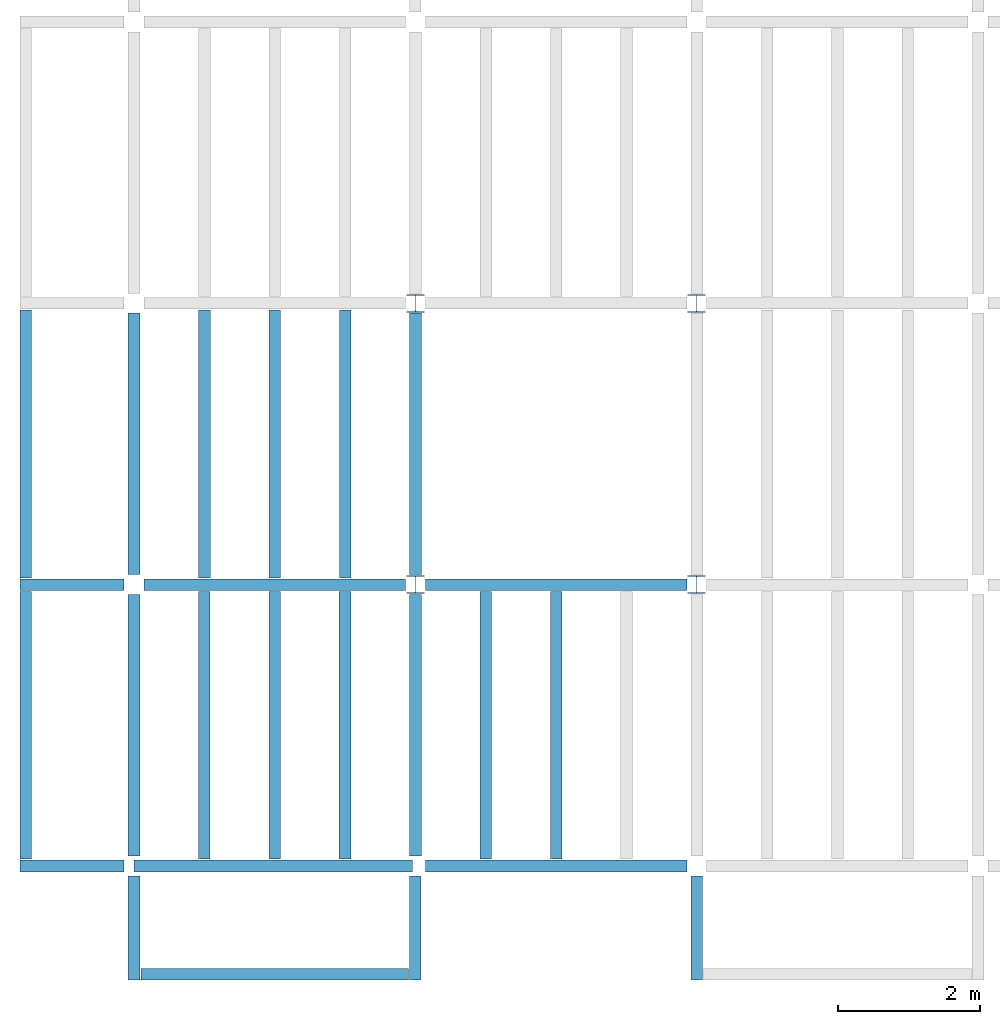
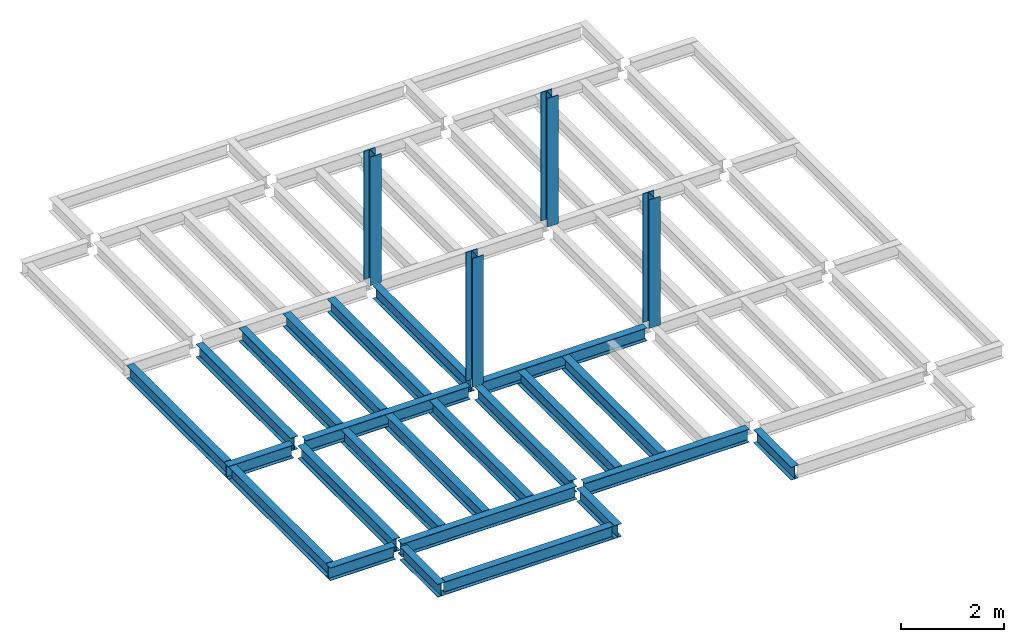
# One storey, part 1 of 3: 24 beams, 4 columns, 3 elements without a shape of their own.
"""IFC4 building model written with IfcOpenShell, lengths in feet."""

from ifc_helpers import new_model, entity, si_unit, converted_unit, derived_unit, direction, frame, origin, origin_2d, place, context, subcontext, project, spatial, line, arc, indexed_curve, i_section, outline, extrude, source, transform, mapped, material, type_object, type_shapes, element, aggregate, save


model = new_model("IFC4")

# Units and contexts
model_context = context("Model", 3, precision=0.0001, world=origin(), true_north=direction((6.123233995736766e-17, 1.0)))
plan_context = context("Plan", 3, precision=0.0001, world=origin(), true_north=direction((6.123233995736766e-17, 1.0)))
body_context = subcontext(model_context, "Body", "Model", "MODEL_VIEW")
ifc_project = project(units=[converted_unit("LENGTHUNIT", "FOOT", entity("IfcLengthMeasure", 0.3048), si_unit("LENGTHUNIT", "METRE"), dimensions=[1, 0, 0, 0, 0, 0, 0]), converted_unit("AREAUNIT", "SQUARE FOOT", entity("IfcAreaMeasure", 0.09290304), si_unit("AREAUNIT", "SQUARE_METRE"), dimensions=[2, 0, 0, 0, 0, 0, 0]), converted_unit("PLANEANGLEUNIT", "DEGREE", entity("IfcPlaneAngleMeasure", 0.017453292519943278), si_unit("PLANEANGLEUNIT", "RADIAN"), dimensions=[0, 0, 0, 0, 0, 0, 0]), converted_unit("VOLUMEUNIT", "CUBIC FOOT", entity("IfcVolumeMeasure", 0.028316846592000004), si_unit("VOLUMEUNIT", "CUBIC_METRE"), dimensions=[3, 0, 0, 0, 0, 0, 0]), si_unit("PRESSUREUNIT", "PASCAL"), derived_unit("MASSDENSITYUNIT", [(si_unit("MASSUNIT", "GRAM", prefix="KILO"), 1), (si_unit("LENGTHUNIT", "METRE"), -3)]), derived_unit("VAPORPERMEABILITYUNIT", [(si_unit("LENGTHUNIT", "METRE"), -1), (si_unit("TIMEUNIT", "SECOND"), 1)]), derived_unit("USERDEFINED", [(si_unit("MASSUNIT", "GRAM", prefix="KILO"), 1), (si_unit("LENGTHUNIT", "METRE"), 3), (si_unit("TIMEUNIT", "SECOND"), -3), (si_unit("ELECTRICCURRENTUNIT", "AMPERE"), -2)]), derived_unit("MODULUSOFELASTICITYUNIT", [(si_unit("MASSUNIT", "GRAM", prefix="KILO"), 1), (si_unit("LENGTHUNIT", "METRE"), -1), (si_unit("TIMEUNIT", "SECOND"), -2)]), derived_unit("THERMALEXPANSIONCOEFFICIENTUNIT", [(si_unit("THERMODYNAMICTEMPERATUREUNIT", "KELVIN"), -1)]), derived_unit("SPECIFICHEATCAPACITYUNIT", [(si_unit("TIMEUNIT", "SECOND"), -2), (si_unit("THERMODYNAMICTEMPERATUREUNIT", "KELVIN"), -1), (si_unit("LENGTHUNIT", "METRE"), 2)]), derived_unit("THERMALCONDUCTANCEUNIT", [(si_unit("MASSUNIT", "GRAM", prefix="KILO"), 1), (si_unit("TIMEUNIT", "SECOND"), -3), (si_unit("THERMODYNAMICTEMPERATUREUNIT", "KELVIN"), -1), (si_unit("LENGTHUNIT", "METRE"), 1)])], contexts=[model_context, plan_context])

# Site, building, storey
site_placement = place(None, origin())
site = spatial("IfcSite", under=ifc_project, at=site_placement, CompositionType="ELEMENT")
building_placement = place(site_placement, origin())
building = spatial("IfcBuilding", under=site, at=building_placement, CompositionType="ELEMENT")
storey_placement = place(building_placement, frame((0.0, 0.0, 129.875)))
storey = spatial("IfcBuildingStorey", under=building, at=storey_placement, Name="STR 14", CompositionType="ELEMENT", Elevation=129.875)

# Columns
ifc_material = material(Name="Steel ASTM A992", Category="Metal")
column_type = type_object("IfcColumnType", Name="W10X49", PredefinedType="COLUMN", material=ifc_material)
shared_shape_1 = source(origin(), body_context, "Body", "SweptSolid", [
    extrude(outline(indexed_curve([(-0.41666666666666663, -0.4166666666666676), (0.41666666666666663, -0.4166666666666676), (0.41666666666666663, -0.3699999999999996), (0.055833333333333846, -0.3699999999999996), (0.02637055078389421, -0.35779611588277277), (0.014166666666666636, -0.32833333333333287), (0.01416666666666665, 0.32833333333333303), (0.026370550783893467, 0.3577961158827727), (0.05583333333333332, 0.3700000000000003), (0.41666666666666663, 0.3700000000000003), (0.41666666666666663, 0.4166666666666656), (-0.41666666666666663, 0.4166666666666656), (-0.41666666666666663, 0.3700000000000003), (-0.05583333333333365, 0.3700000000000003), (-0.02637055078389416, 0.3577961158827734), (-0.014166666666666685, 0.32833333333333387), (-0.014166666666666685, -0.32833333333333264), (-0.026370550783893578, -0.3577961158827721), (-0.055833333333333374, -0.3699999999999996), (-0.41666666666666663, -0.3699999999999996)], segments=[line(1, 2, 3, 4), arc(4, 5, 6), line(6, 7), arc(7, 8, 9), line(9, 10, 11, 12, 13, 14), arc(14, 15, 16), line(16, 17), arc(17, 18, 19), line(19, 20, 1)], self_intersect=False)), frame((0.0, 0.0, 129.875), z_axis=(0.0, 0.0, 1.0), x_axis=(-1.0, 0.0, 0.0)), (0.0, 0.0, 1.0), 9.999999999999972),
])
type_shapes(column_type, [shared_shape_1])
for number, where, z_axis, x_axis, name in (
    (1, (13.0, 13.0, -129.875), (0.0, 0.0, 1.0), (-1.0, 0.0, 0.0), "W10X49"),
    (2, (13.0, 26.0, -129.875), (0.0, 0.0, 1.0), (-1.0, 0.0, 0.0), "W10X49"),
    (3, (26.0, 13.0, -129.875), (0.0, 0.0, 1.0), (-1.0, 0.0, 0.0), "W10X49"),
    (4, (26.0, 26.0, -129.875), (0.0, 0.0, 1.0), (-1.0, 0.0, 0.0), "W10X49"),
):
    element("IfcColumn", number, at=place(storey_placement, frame(where, z_axis=z_axis, x_axis=x_axis)), inside=storey, type_object=column_type, material=ifc_material, Name=name, ObjectType="W Shapes-Column:W10X49", PredefinedType="COLUMN", context=body_context, shape_type="MappedRepresentation", body=[
        mapped(shared_shape_1, transform((0.0, 0.0, 0.0), scale=1.0)),
    ])

# Beams
beam_type_1 = type_object("IfcBeamType", Name="W12X26", PredefinedType="JOIST", material=ifc_material)
shared_shape_2 = source(origin(), body_context, "Body", "SweptSolid", [
    extrude(outline(indexed_curve([(-0.27041666666666714, -0.47666666666666574), (-0.27041666666666714, -0.5083333333333351), (0.2704166666666669, -0.5083333333333351), (0.2704166666666669, -0.47666666666666574), (0.03458333333333309, -0.47666666666666574), (0.016905663803669493, -0.46934433619632937), (0.009583333333333202, -0.4516666666666659), (0.0095833333333332, 0.45166666666666705), (0.01690566380366948, 0.4693443361963307), (0.03458333333333325, 0.4766666666666671), (0.2704166666666669, 0.4766666666666671), (0.2704166666666669, 0.5083333333333312), (-0.2704166666666655, 0.5083333333333312), (-0.2704166666666655, 0.4766666666666671), (-0.034583333333333514, 0.47666666666666707), (-0.016905663803669865, 0.46934433619633054), (-0.009583333333333737, 0.45166666666666694), (-0.009583333333333735, -0.4516666666666658), (-0.01690566380367013, -0.4693443361963295), (-0.03458333333333368, -0.47666666666666574)], segments=[line(1, 2, 3, 4, 5), arc(5, 6, 7), line(7, 8), arc(8, 9, 10), line(10, 11, 12, 13, 14, 15), arc(15, 16, 17), line(17, 18), arc(18, 19, 20), line(20, 1)], self_intersect=False)), frame((-6.103346456692914, 0.0, 0.0), z_axis=(-1.0, 0.0, 0.0), x_axis=(0.0, -1.0, 0.0)), (0.0, 0.0, -1.0), 12.083333333333323),
])
type_shapes(beam_type_1, [shared_shape_2])
for number, where, z_axis, x_axis, name in (
    (5, (0.0, 6.561679790026247, -0.5083333333333258), (0.0, 0.0, 1.0), (0.0, 1.0, 0.0), "W12X26"),
    (6, (13.009583333333428, 6.561679790026203, -0.5083333333333258), (0.0, 0.0, 1.0), (0.0, 1.0, 0.0), "W12X26"),
):
    element("IfcBeam", number, at=place(storey_placement, frame(where, z_axis=z_axis, x_axis=x_axis)), inside=storey, type_object=beam_type_1, material=ifc_material, Name=name, ObjectType="W Shapes:W12X26", PredefinedType="JOIST", context=body_context, shape_type="MappedRepresentation", body=[
        mapped(shared_shape_2, transform((0.0, 0.0, 0.0), scale=1.0)),
    ])
beam_type_2 = type_object("IfcBeamType", Name="W12X26", PredefinedType="JOIST", material=ifc_material)
shared_shape_3 = source(origin(), body_context, "Body", "SweptSolid", [
    extrude(outline(indexed_curve([(-0.27041666666666714, -0.47666666666666574), (-0.27041666666666714, -0.5083333333333351), (0.2704166666666669, -0.5083333333333351), (0.2704166666666669, -0.47666666666666574), (0.03458333333333309, -0.47666666666666574), (0.016905663803669493, -0.46934433619632937), (0.009583333333333202, -0.4516666666666659), (0.0095833333333332, 0.45166666666666705), (0.01690566380366948, 0.4693443361963307), (0.03458333333333325, 0.4766666666666671), (0.2704166666666669, 0.4766666666666671), (0.2704166666666669, 0.5083333333333312), (-0.2704166666666655, 0.5083333333333312), (-0.2704166666666655, 0.4766666666666671), (-0.034583333333333514, 0.47666666666666707), (-0.016905663803669865, 0.46934433619633054), (-0.009583333333333737, 0.45166666666666694), (-0.009583333333333735, -0.4516666666666658), (-0.01690566380367013, -0.4693443361963295), (-0.03458333333333368, -0.47666666666666574)], segments=[line(1, 2, 3, 4, 5), arc(5, 6, 7), line(7, 8), arc(8, 9, 10), line(10, 11, 12, 13, 14, 15), arc(15, 16, 17), line(17, 18), arc(18, 19, 20), line(20, 1)], self_intersect=False)), frame((-6.226706036745409, 0.0, 0.0), z_axis=(-1.0, 0.0, 0.0), x_axis=(0.0, -1.0, 0.0)), (0.0, 0.0, -1.0), 12.08333333333333),
])
type_shapes(beam_type_2, [shared_shape_3])
for number, where, z_axis, x_axis, name in (
    (7, (0.0, 19.68503937007874, -0.5083333333333258), (0.0, 0.0, 1.0), (0.0, 1.0, 0.0), "W12X26"),
    (8, (13.009583333333445, 19.685039370078698, -0.5083333333333258), (0.0, 0.0, 1.0), (0.0, 1.0, 0.0), "W12X26"),
):
    element("IfcBeam", number, at=place(storey_placement, frame(where, z_axis=z_axis, x_axis=x_axis)), inside=storey, type_object=beam_type_2, material=ifc_material, Name=name, ObjectType="W Shapes:W12X26", PredefinedType="JOIST", context=body_context, shape_type="MappedRepresentation", body=[
        mapped(shared_shape_3, transform((0.0, 0.0, 0.0), scale=1.0)),
    ])

# Assembly, beams
assembly_1_placement = place(storey_placement, origin())
assembly_1 = element("IfcElementAssembly", 9, at=assembly_1_placement, inside=storey, Name="Structural Framing System", ObjectType="Structural Beam System:Structural Framing System", AssemblyPlace="NOTDEFINED", PredefinedType="BEAM_GRID")
beam_type_3 = type_object("IfcBeamType", Name="W12X26", PredefinedType="JOIST", material=ifc_material)
shared_shape_4 = source(origin(), body_context, "Body", "SweptSolid", [
    extrude(outline(indexed_curve([(-0.27041666666666714, -0.47666666666666574), (-0.27041666666666714, -0.5083333333333351), (0.2704166666666669, -0.5083333333333351), (0.2704166666666669, -0.47666666666666574), (0.03458333333333309, -0.47666666666666574), (0.016905663803669493, -0.46934433619632937), (0.009583333333333202, -0.4516666666666659), (0.0095833333333332, 0.45166666666666705), (0.01690566380366948, 0.4693443361963307), (0.03458333333333325, 0.4766666666666671), (0.2704166666666669, 0.4766666666666671), (0.2704166666666669, 0.5083333333333312), (-0.2704166666666655, 0.5083333333333312), (-0.2704166666666655, 0.4766666666666671), (-0.034583333333333514, 0.47666666666666707), (-0.016905663803669865, 0.46934433619633054), (-0.009583333333333737, 0.45166666666666694), (-0.009583333333333735, -0.4516666666666658), (-0.01690566380367013, -0.4693443361963295), (-0.03458333333333368, -0.47666666666666574)], segments=[line(1, 2, 3, 4, 5), arc(5, 6, 7), line(7, 8), arc(8, 9, 10), line(10, 11, 12, 13, 14, 15), arc(15, 16, 17), line(17, 18), arc(18, 19, 20), line(20, 1)], self_intersect=False)), frame((-6.187916666666566, 0.0, 0.0), z_axis=(-1.0, 0.0, 0.0), x_axis=(0.0, -1.0, 0.0)), (0.0, 0.0, -1.0), 12.375833333333075),
])
type_shapes(beam_type_3, [shared_shape_4])
beam_1_placement = place(assembly_1_placement, frame((3.250000000000057, 6.499999999999844, -0.5083333333333258), z_axis=(0.0, 0.0, 1.0), x_axis=(0.0, 1.0, 0.0)))
beam_1 = element("IfcBeam", 10, at=beam_1_placement, type_object=beam_type_3, material=ifc_material, Name="W12X26", ObjectType="W Shapes:W12X26", PredefinedType="JOIST", context=body_context, shape_type="MappedRepresentation", body=[
    mapped(shared_shape_4, transform((0.0, 0.0, 0.0), scale=1.0)),
])
beam_2_placement = place(assembly_1_placement, frame((6.500000000000103, 6.4999999999998455, -0.5083333333333258), z_axis=(0.0, 0.0, 1.0), x_axis=(0.0, 1.0, 0.0)))
beam_2 = element("IfcBeam", 11, at=beam_2_placement, type_object=beam_type_3, material=ifc_material, Name="W12X26", ObjectType="W Shapes:W12X26", PredefinedType="JOIST", context=body_context, shape_type="MappedRepresentation", body=[
    mapped(shared_shape_4, transform((0.0, 0.0, 0.0), scale=1.0)),
])
beam_3_placement = place(assembly_1_placement, frame((9.750000000000151, 6.499999999999844, -0.5083333333333258), z_axis=(0.0, 0.0, 1.0), x_axis=(0.0, 1.0, 0.0)))
beam_3 = element("IfcBeam", 12, at=beam_3_placement, type_object=beam_type_3, material=ifc_material, Name="W12X26", ObjectType="W Shapes:W12X26", PredefinedType="JOIST", context=body_context, shape_type="MappedRepresentation", body=[
    mapped(shared_shape_4, transform((0.0, 0.0, 0.0), scale=1.0)),
])
aggregate(assembly_1, [beam_1, beam_2, beam_3])

assembly_2_placement = place(storey_placement, origin())
assembly_2 = element("IfcElementAssembly", 13, at=assembly_2_placement, inside=storey, Name="Structural Framing System", ObjectType="Structural Beam System:Structural Framing System", AssemblyPlace="NOTDEFINED", PredefinedType="BEAM_GRID")
beam_4_placement = place(assembly_2_placement, frame((3.2523958333333844, 19.49999999999968, -0.5083333333333258), z_axis=(0.0, 0.0, 1.0), x_axis=(0.0, 1.0, 0.0)))
beam_4 = element("IfcBeam", 14, at=beam_4_placement, type_object=beam_type_3, material=ifc_material, Name="W12X26", ObjectType="W Shapes:W12X26", PredefinedType="JOIST", context=body_context, shape_type="MappedRepresentation", body=[
    mapped(shared_shape_4, transform((0.0, 0.0, 0.0), scale=1.0)),
])
beam_5_placement = place(assembly_2_placement, frame((6.504791666666738, 19.499999999999666, -0.5083333333333258), z_axis=(0.0, 0.0, 1.0), x_axis=(0.0, 1.0, 0.0)))
beam_5 = element("IfcBeam", 15, at=beam_5_placement, type_object=beam_type_3, material=ifc_material, Name="W12X26", ObjectType="W Shapes:W12X26", PredefinedType="JOIST", context=body_context, shape_type="MappedRepresentation", body=[
    mapped(shared_shape_4, transform((0.0, 0.0, 0.0), scale=1.0)),
])
beam_6_placement = place(assembly_2_placement, frame((9.757187500000091, 19.49999999999966, -0.5083333333333258), z_axis=(0.0, 0.0, 1.0), x_axis=(0.0, 1.0, 0.0)))
beam_6 = element("IfcBeam", 16, at=beam_6_placement, type_object=beam_type_3, material=ifc_material, Name="W12X26", ObjectType="W Shapes:W12X26", PredefinedType="JOIST", context=body_context, shape_type="MappedRepresentation", body=[
    mapped(shared_shape_4, transform((0.0, 0.0, 0.0), scale=1.0)),
])
aggregate(assembly_2, [beam_4, beam_5, beam_6])

assembly_3_placement = place(storey_placement, origin())
assembly_3 = element("IfcElementAssembly", 17, at=assembly_3_placement, inside=storey, Name="Structural Framing System", ObjectType="Structural Beam System:Structural Framing System", AssemblyPlace="NOTDEFINED", PredefinedType="BEAM_GRID")
beam_7_placement = place(assembly_3_placement, frame((16.252395833333445, 6.4999999999998, -0.5083333333333258), z_axis=(0.0, 0.0, 1.0), x_axis=(0.0, 1.0, 0.0)))
beam_7 = element("IfcBeam", 18, at=beam_7_placement, type_object=beam_type_3, material=ifc_material, Name="W12X26", ObjectType="W Shapes:W12X26", PredefinedType="JOIST", context=body_context, shape_type="MappedRepresentation", body=[
    mapped(shared_shape_4, transform((0.0, 0.0, 0.0), scale=1.0)),
])
beam_8_placement = place(assembly_3_placement, frame((19.504791666666776, 6.4999999999998, -0.5083333333333258), z_axis=(0.0, 0.0, 1.0), x_axis=(0.0, 1.0, 0.0)))
beam_8 = element("IfcBeam", 19, at=beam_8_placement, type_object=beam_type_3, material=ifc_material, Name="W12X26", ObjectType="W Shapes:W12X26", PredefinedType="JOIST", context=body_context, shape_type="MappedRepresentation", body=[
    mapped(shared_shape_4, transform((0.0, 0.0, 0.0), scale=1.0)),
])
aggregate(assembly_3, [beam_7, beam_8])

# Beams
for number, where, z_axis, x_axis, name in (
    (20, (-5.0, 6.499999999999858, -0.5083333333333258), (0.0, 0.0, 1.0), (0.0, -1.0, 0.0), "W12X26"),
    (21, (-5.0, 19.499999999999705, -0.5083333333333258), (0.0, 0.0, 1.0), (0.0, 1.0, 0.0), "W12X26"),
):
    element("IfcBeam", number, at=place(storey_placement, frame(where, z_axis=z_axis, x_axis=x_axis)), inside=storey, type_object=beam_type_3, material=ifc_material, Name=name, ObjectType="W Shapes:W12X26", PredefinedType="JOIST", context=body_context, shape_type="MappedRepresentation", body=[
        mapped(shared_shape_4, transform((0.0, 0.0, 0.0), scale=1.0)),
    ])
beam_type_4 = type_object("IfcBeamType", Name="W12X26", PredefinedType="JOIST", material=ifc_material)
shared_shape_5 = source(origin(), body_context, "Body", "SweptSolid", [
    extrude(outline(indexed_curve([(-0.27041666666666714, -0.47666666666666574), (-0.27041666666666714, -0.5083333333333351), (0.2704166666666669, -0.5083333333333351), (0.2704166666666669, -0.47666666666666574), (0.03458333333333309, -0.47666666666666574), (0.016905663803669493, -0.46934433619632937), (0.009583333333333202, -0.4516666666666659), (0.0095833333333332, 0.45166666666666705), (0.01690566380366948, 0.4693443361963307), (0.03458333333333325, 0.4766666666666671), (0.2704166666666669, 0.4766666666666671), (0.2704166666666669, 0.5083333333333312), (-0.2704166666666655, 0.5083333333333312), (-0.2704166666666655, 0.4766666666666671), (-0.034583333333333514, 0.47666666666666707), (-0.016905663803669865, 0.46934433619633054), (-0.009583333333333737, 0.45166666666666694), (-0.009583333333333735, -0.4516666666666658), (-0.01690566380367013, -0.4693443361963295), (-0.03458333333333368, -0.47666666666666574)], segments=[line(1, 2, 3, 4, 5), arc(5, 6, 7), line(7, 8), arc(8, 9, 10), line(10, 11, 12, 13, 14, 15), arc(15, 16, 17), line(17, 18), arc(18, 19, 20), line(20, 1)], self_intersect=False)), frame((-6.0464583333332875, 0.0, 0.0), z_axis=(-1.0, 0.0, 0.0), x_axis=(0.0, -1.0, 0.0)), (0.0, 0.0, -1.0), 12.083333333333329),
])
type_shapes(beam_type_4, [shared_shape_5])
beam_9_placement = place(storey_placement, frame((6.504791666666726, 13.0, -0.5083333333333258)))
element("IfcBeam", 22, at=beam_9_placement, inside=storey, type_object=beam_type_4, material=ifc_material, Name="W12X26", ObjectType="W Shapes:W12X26", PredefinedType="JOIST", context=body_context, shape_type="MappedRepresentation", body=[
    mapped(shared_shape_5, transform((0.0, 0.0, 0.0), scale=1.0)),
])
beam_type_5 = type_object("IfcBeamType", Name="W12X26", PredefinedType="JOIST", material=ifc_material)
shared_shape_6 = source(origin(), body_context, "Body", "SweptSolid", [
    extrude(outline(indexed_curve([(-0.27041666666666714, -0.47666666666666574), (-0.27041666666666714, -0.5083333333333351), (0.2704166666666669, -0.5083333333333351), (0.2704166666666669, -0.47666666666666574), (0.03458333333333309, -0.47666666666666574), (0.016905663803669493, -0.46934433619632937), (0.009583333333333202, -0.4516666666666659), (0.0095833333333332, 0.45166666666666705), (0.01690566380366948, 0.4693443361963307), (0.03458333333333325, 0.4766666666666671), (0.2704166666666669, 0.4766666666666671), (0.2704166666666669, 0.5083333333333312), (-0.2704166666666655, 0.5083333333333312), (-0.2704166666666655, 0.4766666666666671), (-0.034583333333333514, 0.47666666666666707), (-0.016905663803669865, 0.46934433619633054), (-0.009583333333333737, 0.45166666666666694), (-0.009583333333333735, -0.4516666666666658), (-0.01690566380367013, -0.4693443361963295), (-0.03458333333333368, -0.47666666666666574)], segments=[line(1, 2, 3, 4, 5), arc(5, 6, 7), line(7, 8), arc(8, 9, 10), line(10, 11, 12, 13, 14, 15), arc(15, 16, 17), line(17, 18), arc(18, 19, 20), line(20, 1)], self_intersect=False)), frame((-6.051249999999997, 0.0, 0.0), z_axis=(-1.0, 0.0, 0.0), x_axis=(0.0, -1.0, 0.0)), (0.0, 0.0, -1.0), 12.083333333333329),
])
type_shapes(beam_type_5, [shared_shape_6])
beam_10_placement = place(storey_placement, frame((19.50958333333344, 13.0, -0.5083333333333258)))
element("IfcBeam", 23, at=beam_10_placement, inside=storey, type_object=beam_type_5, material=ifc_material, Name="W12X26", ObjectType="W Shapes:W12X26", PredefinedType="JOIST", context=body_context, shape_type="MappedRepresentation", body=[
    mapped(shared_shape_6, transform((0.0, 0.0, 0.0), scale=1.0)),
])
beam_type_6 = type_object("IfcBeamType", Name="W12X26", PredefinedType="JOIST", material=ifc_material)
shared_shape_7 = source(origin(), body_context, "Body", "SweptSolid", [
    extrude(outline(indexed_curve([(-0.27041666666666714, -0.47666666666666574), (-0.27041666666666714, -0.5083333333333351), (0.2704166666666669, -0.5083333333333351), (0.2704166666666669, -0.47666666666666574), (0.03458333333333309, -0.47666666666666574), (0.016905663803669493, -0.46934433619632937), (0.009583333333333202, -0.4516666666666659), (0.0095833333333332, 0.45166666666666705), (0.01690566380366948, 0.4693443361963307), (0.03458333333333325, 0.4766666666666671), (0.2704166666666669, 0.4766666666666671), (0.2704166666666669, 0.5083333333333312), (-0.2704166666666655, 0.5083333333333312), (-0.2704166666666655, 0.4766666666666671), (-0.034583333333333514, 0.47666666666666707), (-0.016905663803669865, 0.46934433619633054), (-0.009583333333333737, 0.45166666666666694), (-0.009583333333333735, -0.4516666666666658), (-0.01690566380367013, -0.4693443361963295), (-0.03458333333333368, -0.47666666666666574)], segments=[line(1, 2, 3, 4, 5), arc(5, 6, 7), line(7, 8), arc(8, 9, 10), line(10, 11, 12, 13, 14, 15), arc(15, 16, 17), line(17, 18), arc(18, 19, 20), line(20, 1)], self_intersect=False)), frame((-5.984778543307067, 0.0, 0.0), z_axis=(-1.0, 0.0, 0.0), x_axis=(0.0, -1.0, 0.0)), (0.0, 0.0, -1.0), 12.08333333333333),
])
type_shapes(beam_type_6, [shared_shape_7])
beam_11_placement = place(storey_placement, frame((19.443111876640486, 0.0, -0.5083333333333258)))
element("IfcBeam", 24, at=beam_11_placement, inside=storey, type_object=beam_type_6, material=ifc_material, Name="W12X26", ObjectType="W Shapes:W12X26", PredefinedType="JOIST", context=body_context, shape_type="MappedRepresentation", body=[
    mapped(shared_shape_7, transform((0.0, 0.0, 0.0), scale=1.0)),
])
beam_type_7 = type_object("IfcBeamType", Name="W12X26", PredefinedType="JOIST", material=ifc_material)
shared_shape_8 = source(origin(), body_context, "Body", "SweptSolid", [
    extrude(outline(indexed_curve([(0.47666666666666574, -0.2704166666666672), (0.5083333333333351, -0.2704166666666672), (0.5083333333333351, 0.27041666666666686), (0.47666666666666574, 0.27041666666666686), (0.47666666666666574, 0.03458333333333307), (0.46934433619632937, 0.016905663803669473), (0.4516666666666659, 0.00958333333333318), (-0.45166666666666705, 0.00958333333333318), (-0.4693443361963307, 0.01690566380366946), (-0.4766666666666671, 0.03458333333333323), (-0.4766666666666671, 0.27041666666666686), (-0.5083333333333312, 0.27041666666666686), (-0.5083333333333312, -0.27041666666666553), (-0.4766666666666671, -0.27041666666666553), (-0.47666666666666707, -0.034583333333333535), (-0.46934433619633054, -0.016905663803669885), (-0.45166666666666694, -0.00958333333333376), (0.4516666666666658, -0.009583333333333756), (0.4693443361963295, -0.01690566380367015), (0.47666666666666574, -0.0345833333333337)], segments=[line(1, 2, 3, 4, 5), arc(5, 6, 7), line(7, 8), arc(8, 9, 10), line(10, 11, 12, 13, 14, 15), arc(15, 16, 17), line(17, 18), arc(18, 19, 20), line(20, 1)], self_intersect=False)), frame((-2.0416666666666208, 0.0, 0.0), z_axis=(1.0, 0.0, 0.0), x_axis=(0.0, 0.0, -1.0)), (0.0, 0.0, 1.0), 4.812083333333336),
])
type_shapes(beam_type_7, [shared_shape_8])
for number, where, z_axis, x_axis, name in (
    (25, (26.0, -2.500000000000538, -0.5083333333333258), (0.0, 0.0, 1.0), (0.0, -1.0, 0.0), "W12X26"),
    (26, (-2.499999999999853, 13.0, -0.5083333333333258), (0.0, 0.0, 1.0), (-1.0, 0.0, 0.0), "W12X26"),
    (27, (-2.4999999999998743, 0.0, -0.5083333333333258), (0.0, 0.0, 1.0), (-1.0, 0.0, 0.0), "W12X26"),
):
    element("IfcBeam", number, at=place(storey_placement, frame(where, z_axis=z_axis, x_axis=x_axis)), inside=storey, type_object=beam_type_7, material=ifc_material, Name=name, ObjectType="W Shapes:W12X26", PredefinedType="JOIST", context=body_context, shape_type="MappedRepresentation", body=[
        mapped(shared_shape_8, transform((0.0, 0.0, 0.0), scale=1.0)),
    ])
beam_type_8 = type_object("IfcBeamType", Name="W12X26", PredefinedType="JOIST", material=ifc_material)
shared_shape_9 = source(origin(), body_context, "Body", "SweptSolid", [
    extrude(outline(indexed_curve([(-0.2704166666666641, -0.5083333333333258), (0.27041666666666764, -0.5083333333333258), (0.27041666666666764, -0.47666666666665947), (0.03458333333333563, -0.47666666666665947), (0.01690566380367997, -0.46934433619631477), (0.009583333333335275, -0.4516666666666538), (0.009583333333333499, 0.4516666666666822), (0.016905663803678195, 0.4693443361963432), (0.03458333333333563, 0.4766666666666879), (0.2704166666666694, 0.4766666666666879), (0.27041666666666764, 0.5083333333333542), (-0.27041666666666586, 0.5083333333333542), (-0.27041666666666586, 0.4766666666666879), (-0.03458333333333208, 0.4766666666666879), (-0.016905663803674642, 0.4693443361963432), (-0.009583333333331723, 0.4516666666666822), (-0.009583333333329946, -0.4516666666666538), (-0.016905663803674642, -0.46934433619631477), (-0.03458333333333208, -0.47666666666665947), (-0.27041666666666586, -0.47666666666665947)], segments=[line(1, 2, 3, 4), arc(4, 5, 6), line(6, 7), arc(7, 8, 9), line(9, 10, 11, 12, 13, 14), arc(14, 15, 16), line(16, 17), arc(17, 18, 19), line(19, 20, 1)], self_intersect=False)), frame((13.0, -0.45833333333387627, 129.36666666666667), z_axis=(0.0, -1.0, 0.0), x_axis=(-1.0, 0.0, 0.0)), (0.0, 0.0, 1.0), 4.812083333333337),
])
type_shapes(beam_type_8, [shared_shape_9])
beam_12_placement = place(storey_placement, frame((0.0, 0.0, -129.875)))
element("IfcBeam", 28, at=beam_12_placement, inside=storey, type_object=beam_type_8, material=ifc_material, Name="W12X26", ObjectType="W Shapes:W12X26", PredefinedType="JOIST", context=body_context, shape_type="MappedRepresentation", body=[
    mapped(shared_shape_9, transform((0.0, 0.0, 0.0), scale=1.0)),
])
beam_type_9 = type_object("IfcBeamType", Name="W12X26", PredefinedType="JOIST", material=ifc_material)
shared_shape_10 = source(origin(), body_context, "Body", "SweptSolid", [
    extrude(outline(indexed_curve([(-0.5083333333333258, -0.270416666666665), (-0.47666666666665947, -0.270416666666665), (-0.47666666666665947, -0.034583333333333854), (-0.46934433619631477, -0.016905663803677307), (-0.4516666666666538, -0.009583333333333499), (0.4516666666666822, -0.009583333333331723), (0.4693443361963432, -0.016905663803677307), (0.4766666666666879, -0.034583333333332966), (0.4766666666666879, -0.27041666666666675), (0.5083333333333542, -0.27041666666666675), (0.5083333333333542, 0.27041666666666675), (0.4766666666666879, 0.27041666666666764), (0.4766666666666879, 0.034583333333333854), (0.4693443361963432, 0.016905663803677307), (0.4516666666666822, 0.009583333333333499), (-0.4516666666666538, 0.009583333333331723), (-0.46934433619631477, 0.016905663803677307), (-0.47666666666665947, 0.034583333333332966), (-0.47666666666665947, 0.27041666666666675), (-0.5083333333333258, 0.27041666666666764)], segments=[line(1, 2, 3), arc(3, 4, 5), line(5, 6), arc(6, 7, 8), line(8, 9, 10, 11, 12, 13), arc(13, 14, 15), line(15, 16), arc(16, 17, 18), line(18, 19, 20, 1)], self_intersect=False)), frame((0.3120833333333186, -5.0, 129.36666666666667), z_axis=(1.0, 0.0, 0.0), x_axis=(0.0, 0.0, -1.0)), (0.0, 0.0, 1.0), 12.37583333333332),
])
type_shapes(beam_type_9, [shared_shape_10])
beam_13_placement = place(storey_placement, frame((0.0, 0.0, -129.875)))
element("IfcBeam", 29, at=beam_13_placement, inside=storey, type_object=beam_type_9, material=ifc_material, Name="W Shapes:W12X26", ObjectType="W Shapes:W12X26", PredefinedType="JOIST", context=body_context, shape_type="MappedRepresentation", body=[
    mapped(shared_shape_10, transform((0.0, 0.0, 0.0), scale=1.0)),
])
beam_type_10 = type_object("IfcBeamType", Name="W12X26", PredefinedType="JOIST", material=ifc_material)
shared_shape_11 = source(origin(), body_context, "Body", "SweptSolid", [
    extrude(outline(indexed_curve([(-0.27041666666666686, -0.5083333333333258), (0.27041666666666553, -0.5083333333333258), (0.27041666666666553, -0.47666666666665947), (0.03458333333333355, -0.47666666666665947), (0.016905663803677563, -0.46934433619631477), (0.009583333333333726, -0.4516666666666538), (0.009583333333331966, 0.4516666666666822), (0.0169056638036777, 0.4693443361963432), (0.034583333333333716, 0.4766666666666879), (0.2704166666666672, 0.4766666666666879), (0.2704166666666672, 0.5083333333333542), (-0.27041666666666686, 0.5083333333333542), (-0.27041666666666686, 0.4766666666666879), (-0.03458333333333308, 0.4766666666666879), (-0.016905663803677026, 0.4693443361963432), (-0.00958333333333316, 0.4516666666666822), (-0.009583333333331428, -0.4516666666666538), (-0.016905663803677078, -0.46934433619631477), (-0.03458333333333319, -0.47666666666665947), (-0.27041666666666686, -0.47666666666665947)], segments=[line(1, 2, 3, 4), arc(4, 5, 6), line(6, 7), arc(7, 8, 9), line(9, 10, 11, 12, 13, 14), arc(14, 15, 16), line(16, 17), arc(17, 18, 19), line(19, 20, 1)], self_intersect=False)), frame((0.0, -0.45833333333383364, 129.36666666666667), z_axis=(0.0, -1.0, 0.0), x_axis=(-1.0, 0.0, 0.0)), (0.0, 0.0, 1.0), 4.812083333333337),
])
type_shapes(beam_type_10, [shared_shape_11])
beam_14_placement = place(storey_placement, frame((0.0, 0.0, -129.875)))
element("IfcBeam", 30, at=beam_14_placement, inside=storey, type_object=beam_type_10, material=ifc_material, Name="W12X26", ObjectType="W Shapes:W12X26", PredefinedType="JOIST", context=body_context, shape_type="MappedRepresentation", body=[
    mapped(shared_shape_11, transform((0.0, 0.0, 0.0), scale=1.0)),
])
beam_type_11 = type_object("IfcBeamType", Name="W12X26", PredefinedType="BEAM")
beam_15_placement = place(storey_placement, frame((0.0, 0.0, -0.5083333333333542), z_axis=(-1.0, 0.0, 0.0), x_axis=(0.0, -1.0, 0.0)))
element("IfcBeam", 31, at=beam_15_placement, inside=storey, type_object=beam_type_11, material=ifc_material, Name="W12X26", ObjectType="W12X26", context=model_context, shape_type="SweptSolid", body=[
    extrude(i_section(OverallWidth=0.5408333333333333, OverallDepth=1.0166666666666666, WebThickness=0.019166666666666665, FlangeThickness=0.03166666666666666, FilletRadius=0.024999999999999998, at=origin_2d()), origin(), (0.0, 0.0, -1.0), 12.876640419947506),
])

save(model, "model.ifc")
